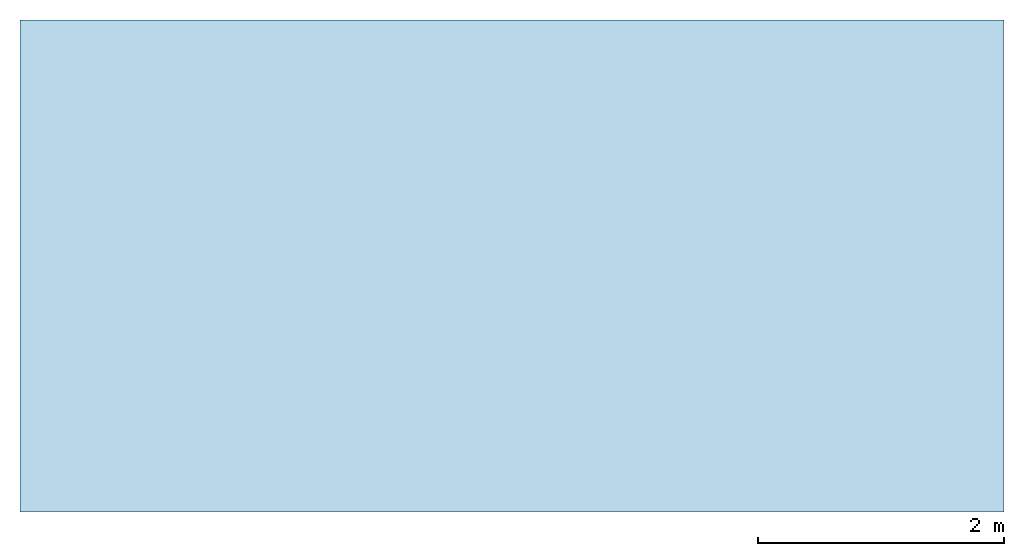
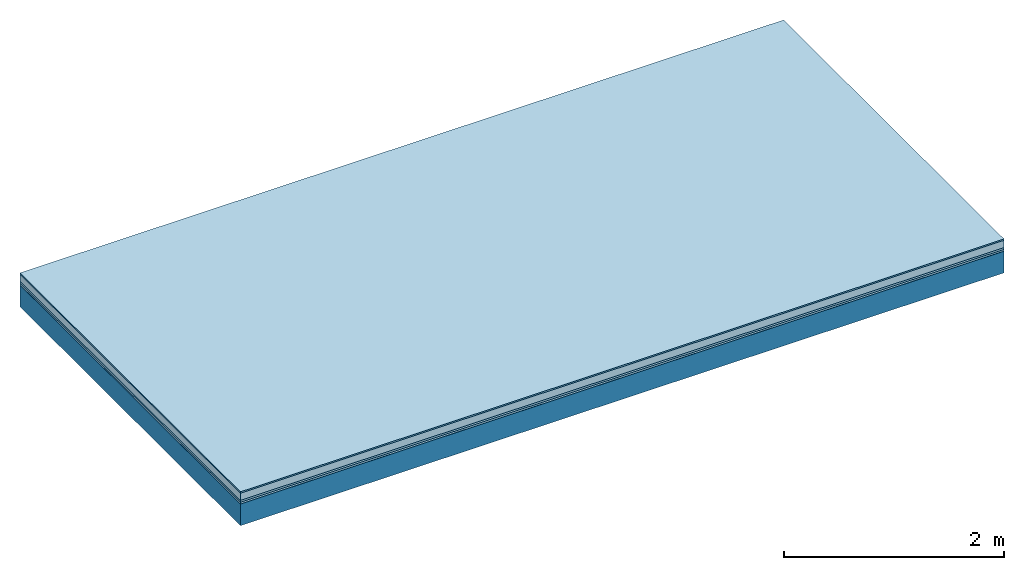
# One storey: 5 plates, 1 member, 1 element without a shape of its own.
"""IFC4 building model written with IfcOpenShell, lengths in metres."""

from ifc_helpers import new_model, si_unit, derived_unit, direction, frame, frame_2d, origin, origin_with_axes, place, context, project, spatial, rectangle, extrude, material, layer, layer_set, type_object, element, aggregate, save


model = new_model("IFC4")

# Units and contexts
plan_context = context("Plan", 3, precision=1e-05, world=origin(), true_north=direction((0.0, 1.0)))
model_context = context("Model", 3, precision=1e-05, world=origin(), true_north=direction((0.0, 1.0)))
ifc_project = project(units=[si_unit("LENGTHUNIT", "METRE"), derived_unit("SOUNDPRESSUREUNIT", [(si_unit("PRESSUREUNIT", "PASCAL", prefix="MICRO"), 0)]), si_unit("ENERGYUNIT", "JOULE", prefix="MEGA"), si_unit("MASSUNIT", "GRAM", prefix="KILO"), derived_unit("THERMALTRANSMITTANCEUNIT", [(si_unit("POWERUNIT", "WATT"), 1), (si_unit("AREAUNIT", "SQUARE_METRE"), -1), (si_unit("THERMODYNAMICTEMPERATUREUNIT", "KELVIN"), -1)]), derived_unit("AREADENSITYUNIT", [(si_unit("MASSUNIT", "GRAM", prefix="KILO"), 1), (si_unit("AREAUNIT", "SQUARE_METRE"), -1)]), derived_unit("USERDEFINED", [(si_unit("ENERGYUNIT", "JOULE", prefix="MEGA"), 1), (si_unit("AREAUNIT", "SQUARE_METRE"), -1)])], contexts=[plan_context, model_context])

# Site, building, storey
site = spatial("IfcSite", under=ifc_project)
building_placement = place(None, origin())
building = spatial("IfcBuilding", under=site, at=building_placement)
storey_placement = place(building_placement, origin())
storey = spatial("IfcBuildingStorey", under=building, at=storey_placement)

# Slab, member, plates
ifc_material_1 = material(Category="11.013")
ifc_layer_1 = layer(ifc_material_1, 0.015, Name="Flooring")
ifc_material_2 = material(Name="Cement screed", Category="04.006")
ifc_layer_2 = layer(ifc_material_2, 0.08, Name="On-material")
ifc_material_3 = material(Name="Wood fiber generic product", Category="10.009")
ifc_layer_3 = layer(ifc_material_3, 0.02, Name="Impact sound insulation")
ifc_material_4 = material()
ifc_layer_4 = layer(ifc_material_4, 0.02, Name="Additional insulation")
ifc_material_5 = material(Name="protection", Category="09.007")
ifc_layer_5 = layer(ifc_material_5, 0.0005, Name="Sub-floor")
ifc_material_6 = material(Name="no composite action")
ifc_layer_6 = layer(ifc_material_6, 0.0, Name="Bond")
ifc_layer_7 = layer(None, 0.24, Name="Supporting structure")
ifc_layer_set = layer_set([ifc_layer_1, ifc_layer_2, ifc_layer_3, ifc_layer_4, ifc_layer_5, ifc_layer_6, ifc_layer_7])
slab_type = type_object("IfcSlabType", Name="A2075", PredefinedType="NOTDEFINED", material=ifc_layer_set)
slab_placement = place(None, frame((0.0, 0.0, 0.0), z_axis=(0.0, 0.0, -1.0), x_axis=(1.0, 0.0, 0.0)))
slab = element("IfcSlab", 1, at=slab_placement, inside=storey, type_object=slab_type, material=ifc_layer_set, Name="Slab #1")
ifc_material_7 = material(Name="Solid timber panel")
member_placement = place(slab_placement, origin())
member = element("IfcMember", 2, at=member_placement, material=ifc_material_7, Name="Supporting structure", context=plan_context, shape_type="SweptSolid", body=[
    extrude(rectangle(XDim=1.0, YDim=0.24, at=frame_2d((0.5, 0.12), x_axis=(1.0, 0.0))), frame((0.0, 4.0, 0.1355), z_axis=(0.0, -1.0, 0.0), x_axis=(1.0, 0.0, 0.0)), (0.0, 0.0, 1.0), 4.0),
    extrude(rectangle(XDim=1.0, YDim=0.24, at=frame_2d((0.5, 0.12), x_axis=(1.0, 0.0))), frame((1.0, 4.0, 0.1355), z_axis=(0.0, -1.0, 0.0), x_axis=(1.0, 0.0, 0.0)), (0.0, 0.0, 1.0), 4.0),
    extrude(rectangle(XDim=1.0, YDim=0.24, at=frame_2d((0.5, 0.12), x_axis=(1.0, 0.0))), frame((2.0, 4.0, 0.1355), z_axis=(0.0, -1.0, 0.0), x_axis=(1.0, 0.0, 0.0)), (0.0, 0.0, 1.0), 4.0),
    extrude(rectangle(XDim=1.0, YDim=0.24, at=frame_2d((0.5, 0.12), x_axis=(1.0, 0.0))), frame((3.0, 4.0, 0.1355), z_axis=(0.0, -1.0, 0.0), x_axis=(1.0, 0.0, 0.0)), (0.0, 0.0, 1.0), 4.0),
    extrude(rectangle(XDim=1.0, YDim=0.24, at=frame_2d((0.5, 0.12), x_axis=(1.0, 0.0))), frame((4.0, 4.0, 0.1355), z_axis=(0.0, -1.0, 0.0), x_axis=(1.0, 0.0, 0.0)), (0.0, 0.0, 1.0), 4.0),
    extrude(rectangle(XDim=1.0, YDim=0.24, at=frame_2d((0.5, 0.12), x_axis=(1.0, 0.0))), frame((5.0, 4.0, 0.1355), z_axis=(0.0, -1.0, 0.0), x_axis=(1.0, 0.0, 0.0)), (0.0, 0.0, 1.0), 4.0),
    extrude(rectangle(XDim=1.0, YDim=0.24, at=frame_2d((0.5, 0.12), x_axis=(1.0, 0.0))), frame((6.0, 4.0, 0.1355), z_axis=(0.0, -1.0, 0.0), x_axis=(1.0, 0.0, 0.0)), (0.0, 0.0, 1.0), 4.0),
    extrude(rectangle(XDim=1.0, YDim=0.24, at=frame_2d((0.5, 0.12), x_axis=(1.0, 0.0))), frame((7.0, 4.0, 0.1355), z_axis=(0.0, -1.0, 0.0), x_axis=(1.0, 0.0, 0.0)), (0.0, 0.0, 1.0), 4.0),
])
plate_1_placement = place(slab_placement, origin())
plate_1 = element("IfcPlate", 3, at=plate_1_placement, material=ifc_material_1, Name="Flooring", context=plan_context, shape_type="SweptSolid", body=[
    extrude(rectangle(XDim=8.0, YDim=4.0, at=frame_2d((4.0, 2.0), x_axis=(1.0, 0.0))), origin_with_axes(), (0.0, 0.0, 1.0), 0.015),
])
plate_2_placement = place(slab_placement, origin())
plate_2 = element("IfcPlate", 4, at=plate_2_placement, material=ifc_material_2, Name="On-material", context=plan_context, shape_type="SweptSolid", body=[
    extrude(rectangle(XDim=8.0, YDim=4.0, at=frame_2d((4.0, 2.0), x_axis=(1.0, 0.0))), frame((0.0, 0.0, 0.015), z_axis=(0.0, 0.0, 1.0), x_axis=(1.0, 0.0, 0.0)), (0.0, 0.0, 1.0), 0.08),
])
plate_3_placement = place(slab_placement, origin())
plate_3 = element("IfcPlate", 5, at=plate_3_placement, material=ifc_material_3, Name="Impact sound insulation", context=plan_context, shape_type="SweptSolid", body=[
    extrude(rectangle(XDim=8.0, YDim=4.0, at=frame_2d((4.0, 2.0), x_axis=(1.0, 0.0))), frame((0.0, 0.0, 0.095), z_axis=(0.0, 0.0, 1.0), x_axis=(1.0, 0.0, 0.0)), (0.0, 0.0, 1.0), 0.02),
])
plate_4_placement = place(slab_placement, origin())
plate_4 = element("IfcPlate", 6, at=plate_4_placement, material=ifc_material_4, Name="Additional insulation", context=plan_context, shape_type="SweptSolid", body=[
    extrude(rectangle(XDim=8.0, YDim=4.0, at=frame_2d((4.0, 2.0), x_axis=(1.0, 0.0))), frame((0.0, 0.0, 0.115), z_axis=(0.0, 0.0, 1.0), x_axis=(1.0, 0.0, 0.0)), (0.0, 0.0, 1.0), 0.02),
])
plate_5_placement = place(slab_placement, origin())
plate_5 = element("IfcPlate", 7, at=plate_5_placement, material=ifc_material_5, Name="Sub-floor", context=plan_context, shape_type="SweptSolid", body=[
    extrude(rectangle(XDim=8.0, YDim=4.0, at=frame_2d((4.0, 2.0), x_axis=(1.0, 0.0))), frame((0.0, 0.0, 0.135), z_axis=(0.0, 0.0, 1.0), x_axis=(1.0, 0.0, 0.0)), (0.0, 0.0, 1.0), 0.0005),
])
aggregate(slab, [plate_1, plate_2, plate_3, plate_4, plate_5, member])

save(model, "model.ifc")
